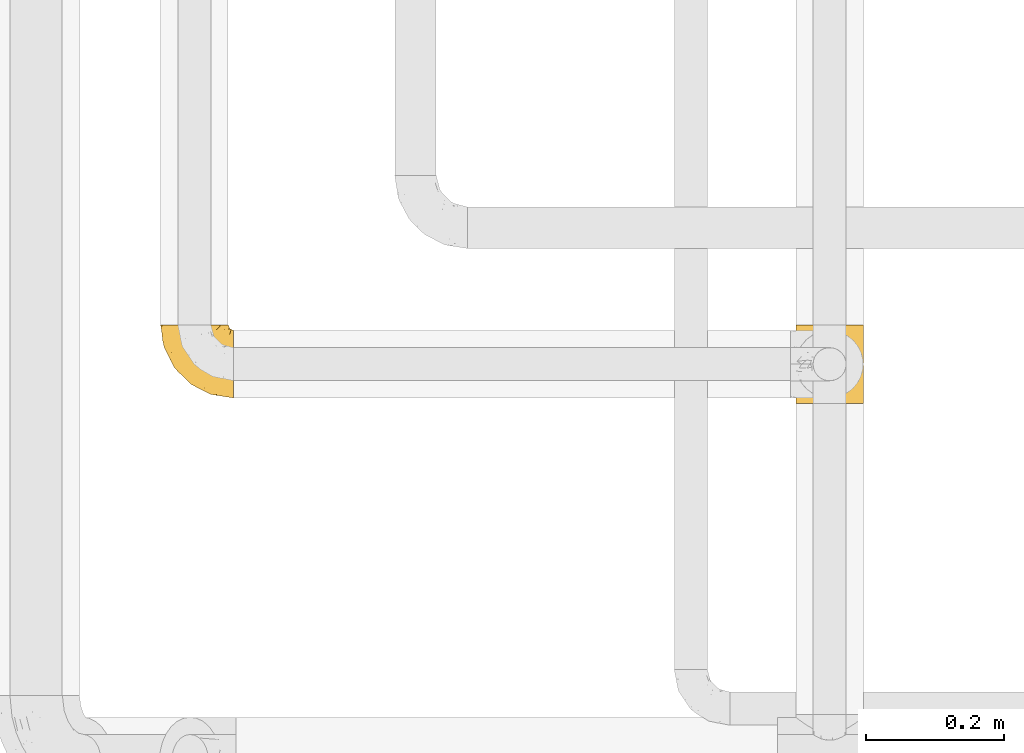
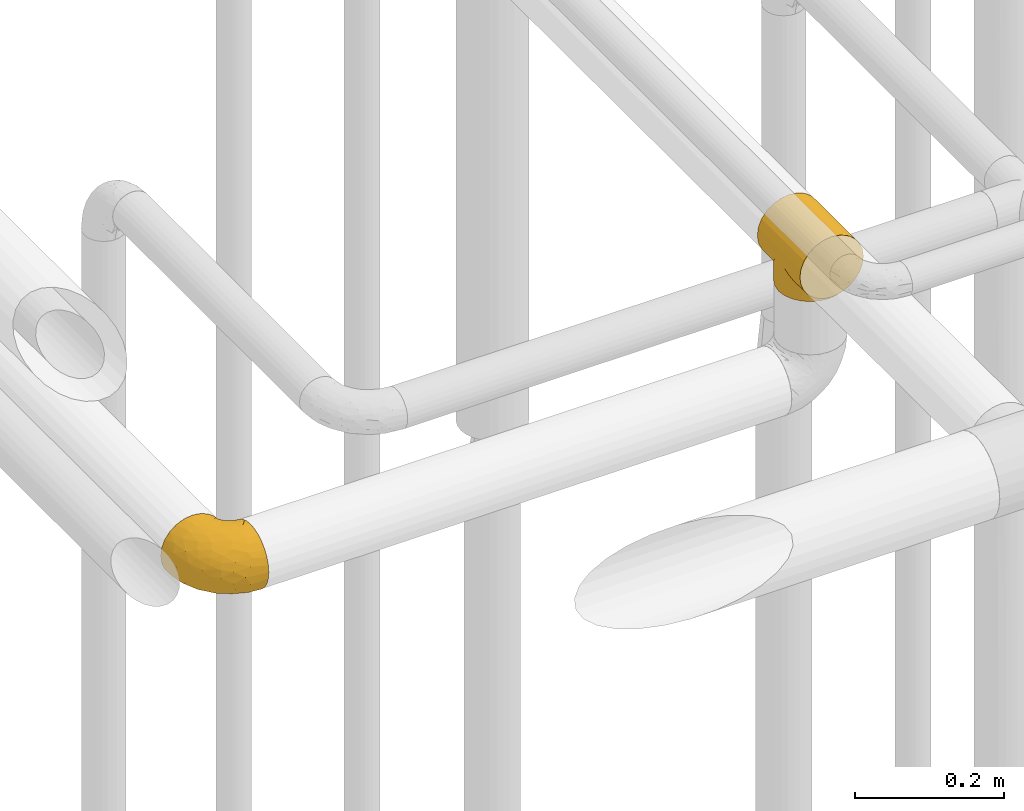
# One storey, part 421 of 827: 2 coverings.
"""IFC2X3 building model written with IfcOpenShell, lengths in millimetres."""

from ifc_helpers import new_model, entity, si_unit, converted_unit, derived_unit, direction, frame, origin, place, context, subcontext, project, spatial, faceted_brep, element, save


model = new_model("IFC2X3")

# Units and contexts
model_context = context("Model", 3, precision=0.01, world=origin(), true_north=direction((6.12303176911189e-17, 1.0)))
body_context = subcontext(model_context, "Body", "Model", "MODEL_VIEW")
ifc_project = project(units=[si_unit("LENGTHUNIT", "METRE", prefix="MILLI"), si_unit("AREAUNIT", "SQUARE_METRE"), si_unit("VOLUMEUNIT", "CUBIC_METRE"), converted_unit("PLANEANGLEUNIT", "DEGREE", entity("IfcRatioMeasure", 0.0174532925199433), si_unit("PLANEANGLEUNIT", "RADIAN"), dimensions=[0, 0, 0, 0, 0, 0, 0]), si_unit("MASSUNIT", "GRAM", prefix="KILO"), derived_unit("MASSDENSITYUNIT", [(si_unit("MASSUNIT", "GRAM", prefix="KILO"), 1), (si_unit("LENGTHUNIT", "METRE"), -3)]), derived_unit("MOMENTOFINERTIAUNIT", [(si_unit("LENGTHUNIT", "METRE"), 4)]), si_unit("TIMEUNIT", "SECOND"), si_unit("FREQUENCYUNIT", "HERTZ"), si_unit("THERMODYNAMICTEMPERATUREUNIT", "DEGREE_CELSIUS"), derived_unit("THERMALTRANSMITTANCEUNIT", [(si_unit("MASSUNIT", "GRAM", prefix="KILO"), 1), (si_unit("THERMODYNAMICTEMPERATUREUNIT", "KELVIN"), -1), (si_unit("TIMEUNIT", "SECOND"), -3)]), derived_unit("VOLUMETRICFLOWRATEUNIT", [(si_unit("LENGTHUNIT", "METRE"), 3), (si_unit("TIMEUNIT", "SECOND"), -1)]), derived_unit("MASSFLOWRATEUNIT", [(si_unit("MASSUNIT", "GRAM", prefix="KILO"), 1), (si_unit("TIMEUNIT", "SECOND"), -1)]), derived_unit("ROTATIONALFREQUENCYUNIT", [(si_unit("TIMEUNIT", "SECOND"), -1)]), si_unit("ELECTRICCURRENTUNIT", "AMPERE"), si_unit("ELECTRICVOLTAGEUNIT", "VOLT"), si_unit("POWERUNIT", "WATT"), si_unit("FORCEUNIT", "NEWTON", prefix="KILO"), si_unit("ILLUMINANCEUNIT", "LUX"), si_unit("LUMINOUSFLUXUNIT", "LUMEN"), si_unit("LUMINOUSINTENSITYUNIT", "CANDELA"), derived_unit("USERDEFINED", [(si_unit("MASSUNIT", "GRAM", prefix="KILO"), -1), (si_unit("LENGTHUNIT", "METRE"), -2), (si_unit("TIMEUNIT", "SECOND"), 3), (si_unit("LUMINOUSFLUXUNIT", "LUMEN"), 1)]), derived_unit("LINEARVELOCITYUNIT", [(si_unit("LENGTHUNIT", "METRE"), 1), (si_unit("TIMEUNIT", "SECOND"), -1)]), si_unit("PRESSUREUNIT", "PASCAL"), derived_unit("USERDEFINED", [(si_unit("LENGTHUNIT", "METRE"), -2), (si_unit("MASSUNIT", "GRAM", prefix="KILO"), 1), (si_unit("TIMEUNIT", "SECOND"), -2)]), derived_unit("LINEARFORCEUNIT", [(si_unit("MASSUNIT", "GRAM", prefix="KILO"), 1), (si_unit("LENGTHUNIT", "METRE"), 1), (si_unit("TIMEUNIT", "SECOND"), -2), (si_unit("LENGTHUNIT", "METRE"), -1)]), derived_unit("PLANARFORCEUNIT", [(si_unit("MASSUNIT", "GRAM", prefix="KILO"), 1), (si_unit("LENGTHUNIT", "METRE"), 1), (si_unit("TIMEUNIT", "SECOND"), -2), (si_unit("LENGTHUNIT", "METRE"), -2)])], contexts=[model_context])

# Site, building, storey
site_placement = place(None, origin())
site = spatial("IfcSite", under=ifc_project, at=site_placement, CompositionType="ELEMENT")
building_placement = place(site_placement, origin())
building = spatial("IfcBuilding", under=site, at=building_placement, CompositionType="ELEMENT")
storey_placement = place(building_placement, frame((0.0, 0.0, 28200.0)))
storey = spatial("IfcBuildingStorey", under=building, at=storey_placement, Name="08", CompositionType="ELEMENT", Elevation=28200.0)

# Coverings
covering_1_placement = place(storey_placement, frame((53070.31, 16591.32, 2642.23)))
element("IfcCovering", 1, at=covering_1_placement, inside=storey, Name=":ADSK_", ObjectType=":ADSK_", PredefinedType="INSULATION", context=body_context, shape_type="Brep", body=[
    faceted_brep([(2.04, 63.68, 50.44), (1.6, 114.07, 56.99), (3.27, 114.05, 44.27), (8.18, 114.03, 32.41), (5.67, 76.64, 37.44), (13.2, 88.74, 25.3), (15.99, 114.02, 22.23), (8.92, 82.85, 31.21), (1.6, 57.07, 57.07), (2.04, 50.44, 50.46), (1.6, 0.07, 57.15), (46.1, 105.71, 8.29), (44.38, 114.0, 8.68), (47.57, 114.0, 8.26), (3.39, 70.22, 43.88), (50.75, 106.15, 7.85), (50.75, 114.0, 7.84), (47.57, 0.0, 8.41), (50.75, 7.85, 7.98), (50.75, 0.0, 8.0), (18.57, 94.17, 19.86), (26.17, 114.01, 14.42), (32.1, 114.01, 11.97), (38.02, 114.0, 9.51), (37.11, 104.01, 10.0), (41.45, 105.26, 8.74), (25.1, 98.94, 15.08), (32.77, 102.75, 11.26), (41.2, 114.0, 9.1), (53.93, 114.0, 8.26), (57.11, 114.0, 8.68), (55.89, 105.61, 8.4), (61.04, 105.06, 8.94), (60.29, 114.0, 9.1), (63.47, 114.0, 9.51), (70.52, 102.0, 12.01), (69.39, 114.01, 11.97), (75.32, 114.01, 14.42), (65.78, 103.53, 10.47), (78.69, 97.44, 16.58), (80.41, 114.01, 18.33), (85.44, 91.84, 22.2), (74.6, 99.72, 14.29), (53.32, 105.88, 8.12), (85.5, 114.02, 22.23), (90.79, 85.52, 28.53), (93.31, 114.03, 32.41), (94.84, 78.75, 35.33), (98.22, 114.05, 44.27), (99.34, 64.41, 49.71), (99.9, 114.07, 56.99), (53.32, 8.12, 8.26), (97.67, 71.67, 42.43), (99.9, 57.07, 57.07), (99.34, 49.71, 49.73), (99.9, 0.07, 57.15), (75.32, 0.13, 99.71), (63.47, 0.13, 104.62), (50.75, 0.13, 106.3), (38.02, 0.13, 104.62), (26.17, 0.13, 99.71), (15.99, 0.12, 91.9), (8.18, 0.1, 81.72), (3.27, 0.08, 69.87), (3.27, 0.05, 44.42), (8.18, 0.03, 32.57), (15.99, 0.02, 22.39), (26.17, 0.01, 14.58), (32.1, 0.01, 12.13), (38.02, 0.0, 9.67), (41.2, 0.0, 9.25), (44.38, 0.0, 8.83), (53.93, 0.0, 8.41), (57.11, 0.0, 8.83), (60.29, 0.0, 9.25), (63.47, 0.0, 9.67), (69.39, 0.01, 12.13), (75.32, 0.01, 14.58), (80.41, 0.01, 18.49), (85.5, 0.02, 22.39), (93.31, 0.03, 32.57), (98.22, 0.05, 44.42), (98.22, 0.08, 69.87), (93.31, 0.1, 81.72), (85.5, 0.12, 91.9), (3.27, 114.08, 69.71), (8.18, 114.1, 81.56), (15.99, 114.12, 91.74), (26.17, 114.13, 99.55), (38.02, 114.13, 104.46), (50.75, 114.13, 106.14), (63.47, 114.13, 104.46), (75.32, 114.13, 99.55), (85.5, 114.12, 91.74), (93.31, 114.1, 81.56), (98.22, 114.08, 69.71), (3.39, 43.88, 43.91), (5.67, 37.44, 37.49), (46.1, 8.29, 8.43), (8.92, 31.21, 31.28), (13.2, 25.3, 25.39), (41.45, 8.74, 8.87), (18.57, 19.86, 19.96), (25.1, 15.08, 15.19), (37.11, 10.0, 10.13), (32.77, 11.26, 11.38), (70.52, 12.01, 12.13), (65.78, 10.47, 10.6), (78.69, 16.58, 16.69), (61.04, 8.94, 9.07), (85.44, 22.2, 22.3), (74.6, 14.29, 14.41), (55.89, 8.4, 8.53), (94.84, 35.33, 35.39), (97.67, 42.43, 42.47), (90.79, 28.53, 28.61), (3.27, 69.71, 0.05), (8.18, 81.56, 0.03), (15.99, 91.74, 0.02), (26.17, 99.55, 0.01), (32.1, 102.01, 0.01), (38.02, 104.46, 0.0), (41.2, 104.88, 0.0), (44.38, 105.3, 0.0), (47.57, 105.72, 0.0), (50.75, 106.14, 0.0), (53.93, 105.72, 0.0), (57.11, 105.3, 0.0), (60.29, 104.88, 0.0), (63.47, 104.46, 0.0), (69.39, 102.01, 0.01), (75.32, 99.55, 0.01), (80.41, 95.65, 0.01), (85.5, 91.74, 0.02), (93.31, 81.56, 0.03), (98.22, 69.71, 0.05), (99.9, 56.99, 0.07), (98.22, 44.27, 0.08), (93.31, 32.41, 0.1), (85.5, 22.23, 0.12), (80.41, 18.33, 0.12), (75.32, 14.42, 0.13), (69.39, 11.97, 0.13), (63.47, 9.51, 0.13), (60.29, 9.1, 0.13), (57.11, 8.68, 0.13), (53.93, 8.26, 0.13), (50.75, 7.84, 0.13), (47.57, 8.26, 0.13), (44.38, 8.68, 0.13), (41.2, 9.1, 0.13), (38.02, 9.51, 0.13), (32.1, 11.97, 0.13), (26.17, 14.42, 0.13), (15.99, 22.23, 0.12), (8.18, 32.41, 0.1), (3.27, 44.27, 0.08), (1.6, 56.99, 0.07)], [[[0, 1, 2]], [[2, 3, 4]], [[5, 3, 6]], [[5, 7, 3]], [[0, 8, 1]], [[8, 9, 10]], [[11, 12, 13]], [[4, 14, 2]], [[7, 4, 3]], [[0, 2, 14]], [[15, 13, 16]], [[17, 18, 19]], [[20, 6, 21]], [[22, 23, 24]], [[15, 11, 13]], [[23, 25, 24]], [[26, 20, 21]], [[27, 21, 22]], [[27, 22, 24]], [[25, 12, 11]], [[25, 23, 28, 12]], [[26, 21, 27]], [[6, 20, 5]], [[29, 30, 31]], [[32, 30, 33, 34]], [[35, 36, 37]], [[38, 36, 35]], [[38, 32, 34]], [[39, 37, 40]], [[41, 39, 40]], [[35, 37, 39, 42]], [[43, 16, 29]], [[40, 44, 41]], [[45, 44, 46]], [[47, 46, 48]], [[49, 48, 50]], [[47, 45, 46]], [[16, 43, 15]], [[51, 19, 18]], [[49, 52, 48]], [[53, 49, 50]], [[54, 53, 55]], [[30, 32, 31]], [[47, 48, 52]], [[36, 38, 34]], [[44, 45, 41]], [[29, 31, 43]], [[56, 57, 58, 59, 60, 61, 62, 63, 10, 64, 65, 66, 67, 68, 69, 70, 71, 17, 19, 72, 73, 74, 75, 76, 77, 78, 79, 80, 81, 55, 82, 83, 84]], [[85, 86, 87, 88, 89, 90, 91, 92, 93, 94, 95, 50, 48, 46, 44, 40, 37, 36, 34, 33, 30, 29, 16, 13, 12, 28, 23, 22, 21, 6, 3, 2, 1]], [[88, 87, 61, 60]], [[58, 90, 89, 59]], [[89, 88, 60, 59]], [[62, 86, 85, 63]], [[1, 8, 10, 63, 85]], [[61, 87, 86, 62]], [[96, 97, 64]], [[18, 17, 98]], [[9, 96, 64]], [[10, 9, 64]], [[65, 99, 100]], [[65, 64, 97]], [[71, 101, 98]], [[65, 100, 66]], [[99, 65, 97]], [[102, 103, 67]], [[104, 68, 105]], [[104, 101, 69]], [[68, 104, 69]], [[103, 105, 67]], [[66, 102, 67]], [[101, 71, 70, 69]], [[68, 67, 105]], [[98, 17, 71]], [[102, 66, 100]], [[106, 76, 107]], [[106, 77, 76]], [[77, 108, 78]], [[109, 75, 74, 73]], [[110, 78, 108]], [[111, 108, 77, 106]], [[19, 51, 72]], [[109, 73, 112]], [[72, 51, 112]], [[76, 75, 107]], [[110, 79, 78]], [[75, 109, 107]], [[113, 114, 81]], [[114, 54, 81]], [[79, 115, 80]], [[115, 79, 110]], [[113, 80, 115]], [[113, 81, 80]], [[54, 55, 81]], [[112, 73, 72]], [[53, 50, 95, 82, 55]], [[82, 95, 94, 83]], [[94, 93, 84, 83]], [[84, 93, 92, 56]], [[56, 92, 91, 57]], [[57, 91, 90, 58]], [[116, 117, 118, 119, 120, 121, 122, 123, 124, 125, 126, 127, 128, 129, 130, 131, 132, 133, 134, 135, 136, 137, 138, 139, 140, 141, 142, 143, 144, 145, 146, 147, 148, 149, 150, 151, 152, 153, 154, 155, 156, 157]], [[25, 123, 122, 121]], [[119, 118, 20]], [[15, 124, 11]], [[27, 120, 119]], [[124, 15, 125]], [[124, 123, 11]], [[120, 24, 121]], [[26, 27, 119]], [[20, 26, 119]], [[24, 120, 27]], [[25, 121, 24]], [[118, 5, 20]], [[7, 5, 117]], [[117, 5, 118]], [[4, 117, 116]], [[0, 116, 157]], [[4, 7, 117]], [[0, 14, 116]], [[8, 0, 157]], [[4, 116, 14]], [[123, 25, 11]], [[9, 157, 156]], [[156, 155, 97]], [[100, 155, 154]], [[100, 99, 155]], [[9, 8, 157]], [[98, 149, 148]], [[97, 96, 156]], [[99, 97, 155]], [[9, 156, 96]], [[18, 148, 147]], [[102, 154, 153]], [[152, 151, 104]], [[18, 98, 148]], [[151, 101, 104]], [[103, 102, 153]], [[105, 153, 152]], [[105, 152, 104]], [[101, 149, 98]], [[101, 151, 150, 149]], [[103, 153, 105]], [[154, 102, 100]], [[146, 145, 112]], [[109, 145, 144, 143]], [[106, 142, 141]], [[107, 142, 106]], [[107, 109, 143]], [[108, 141, 140]], [[110, 108, 140]], [[106, 141, 108, 111]], [[51, 147, 146]], [[140, 139, 110]], [[115, 139, 138]], [[113, 138, 137]], [[54, 137, 136]], [[113, 115, 138]], [[147, 51, 18]], [[54, 114, 137]], [[53, 54, 136]], [[145, 109, 112]], [[113, 137, 114]], [[142, 107, 143]], [[139, 115, 110]], [[146, 112, 51]], [[49, 136, 135]], [[135, 134, 47]], [[45, 134, 133]], [[45, 47, 134]], [[43, 125, 15]], [[49, 53, 136]], [[32, 129, 128, 127]], [[47, 52, 135]], [[49, 135, 52]], [[31, 127, 126]], [[131, 35, 42, 39]], [[125, 43, 126]], [[39, 132, 131]], [[130, 129, 38]], [[43, 31, 126]], [[41, 133, 132]], [[41, 132, 39]], [[35, 130, 38]], [[32, 127, 31]], [[35, 131, 130]], [[129, 32, 38]], [[133, 41, 45]]]),
])
covering_2_placement = place(storey_placement, frame((52147.53, 16597.64, 2447.42)))
element("IfcCovering", 2, at=covering_2_placement, inside=storey, Name=":ADSK_", ObjectType=":ADSK_", PredefinedType="INSULATION", context=body_context, shape_type="Brep", body=[
    faceted_brep([(107.75, 50.75, 99.9), (107.75, 39.8, 98.66), (107.75, 29.41, 95.02), (107.75, 20.09, 89.17), (107.75, 12.31, 81.38), (107.75, 6.46, 72.06), (107.75, 2.83, 61.68), (107.75, 1.6, 50.75), (107.75, 2.83, 39.8), (107.75, 6.47, 29.41), (107.75, 12.32, 20.09), (107.75, 20.11, 12.31), (107.75, 29.43, 6.46), (107.75, 39.81, 2.83), (107.75, 50.75, 1.6), (107.75, 56.45, 2.24), (107.75, 61.69, 2.83), (107.75, 66.88, 4.65), (107.75, 72.08, 6.47), (107.75, 81.4, 12.32), (107.75, 89.18, 20.11), (107.75, 95.03, 29.43), (107.75, 98.66, 39.81), (107.75, 99.9, 50.75), (107.75, 98.66, 61.69), (107.75, 95.02, 72.08), (107.75, 89.17, 81.4), (107.75, 81.38, 89.18), (107.75, 72.06, 95.03), (107.75, 66.87, 96.85), (107.75, 61.68, 98.66), (107.75, 56.45, 99.25), (107.75, 53.6, 99.57), (98.22, 107.75, 38.02), (93.31, 107.75, 26.17), (89.4, 107.75, 21.08), (85.5, 107.75, 15.99), (80.41, 107.75, 12.09), (75.32, 107.75, 8.18), (69.39, 107.75, 5.73), (63.47, 107.75, 3.27), (56.48, 107.75, 2.35), (53.61, 107.75, 1.97), (50.75, 107.75, 1.6), (38.02, 107.75, 3.27), (26.17, 107.75, 8.18), (15.99, 107.75, 15.99), (8.18, 107.75, 26.17), (3.27, 107.75, 38.02), (1.6, 107.75, 50.75), (3.27, 107.75, 63.47), (8.18, 107.75, 75.32), (15.99, 107.75, 85.5), (26.17, 107.75, 93.31), (38.02, 107.75, 98.22), (50.75, 107.75, 99.9), (56.48, 107.75, 99.14), (63.47, 107.75, 98.22), (69.39, 107.75, 95.77), (75.32, 107.75, 93.31), (80.41, 107.75, 89.4), (85.5, 107.75, 85.5), (89.4, 107.75, 80.41), (93.31, 107.75, 75.32), (98.22, 107.75, 63.47), (99.9, 107.75, 50.75), (27.53, 39.38, 59.31), (25.32, 49.75, 73.08), (16.29, 57.38, 63.72), (6.79, 74.94, 50.75), (4.51, 85.97, 58.64), (3.51, 95.66, 50.75), (17.47, 67.82, 76.74), (7.6, 83.09, 67.68), (12.27, 89.16, 78.92), (70.89, 37.01, 94.31), (87.17, 43.46, 98.76), (67.3, 51.79, 98.4), (31.65, 85.58, 94.57), (33.58, 62.84, 89.91), (47.23, 62.77, 96.32), (43.26, 88.17, 98.79), (55.08, 85.93, 99.9), (53.99, 91.42, 99.9), (52.9, 96.91, 99.9), (52.36, 99.62, 99.9), (51.82, 102.33, 99.9), (21.5, 82.57, 87.31), (89.94, 32.75, 95.61), (60.45, 13.79, 60.43), (83.0, 6.77, 65.24), (64.79, 16.46, 72.87), (85.93, 55.08, 99.9), (81.31, 58.17, 99.9), (76.69, 61.26, 99.9), (72.06, 64.35, 99.9), (67.44, 67.44, 99.9), (88.74, 24.18, 90.65), (45.98, 23.37, 63.14), (47.13, 49.76, 91.89), (89.4, 9.84, 75.25), (95.66, 3.51, 50.75), (28.5, 55.75, 82.18), (42.81, 42.34, 85.08), (38.28, 37.78, 76.93), (45.35, 21.87, 50.75), (33.61, 33.61, 50.75), (82.57, 17.1, 83.02), (105.04, 51.28, 99.9), (102.33, 51.82, 99.9), (96.91, 52.9, 99.9), (91.42, 53.99, 99.9), (65.92, 28.01, 87.13), (53.11, 28.99, 80.85), (54.37, 69.9, 99.17), (74.94, 6.79, 50.75), (64.35, 72.06, 99.9), (61.26, 76.69, 99.9), (58.17, 81.31, 99.9), (21.87, 45.35, 50.75), (34.79, 34.79, 67.61), (48.48, 25.72, 72.25), (60.15, 14.33, 50.75), (14.33, 60.15, 50.75), (99.07, 62.38, 98.69), (60.55, 100.57, 99.01), (64.18, 91.06, 98.79), (64.36, 97.66, 98.29), (103.17, 97.55, 68.51), (101.69, 93.65, 76.82), (87.75, 66.85, 98.54), (89.38, 61.93, 99.3), (88.34, 101.4, 83.57), (82.14, 100.07, 89.47), (94.51, 101.36, 75.76), (89.64, 95.94, 84.86), (98.41, 96.3, 75.89), (99.71, 101.98, 64.77), (89.37, 85.88, 90.83), (88.21, 78.88, 94.62), (95.2, 82.8, 90.37), (79.14, 102.58, 91.18), (101.22, 82.88, 88.65), (99.41, 88.57, 84.11), (84.72, 88.67, 91.75), (97.47, 69.08, 96.86), (102.19, 102.19, 50.75), (104.02, 100.06, 58.97), (82.66, 70.56, 98.37), (95.42, 91.07, 83.91), (78.67, 77.56, 97.52), (72.69, 96.59, 95.55), (66.46, 86.38, 98.76), (75.3, 91.79, 95.26), (72.74, 81.71, 98.04), (82.93, 94.11, 90.65), (99.27, 76.09, 93.51), (93.51, 76.91, 94.16), (67.35, 81.44, 99.1), (94.51, 101.37, 25.73), (82.94, 94.12, 10.84), (88.33, 101.41, 17.92), (89.64, 95.96, 16.64), (103.62, 96.22, 30.44), (87.74, 66.85, 2.95), (89.38, 61.94, 2.19), (81.31, 58.17, 1.6), (97.47, 69.1, 4.63), (99.41, 88.58, 17.39), (51.28, 105.04, 1.6), (52.9, 96.91, 1.6), (51.82, 102.33, 1.6), (101.21, 82.9, 12.86), (95.19, 82.82, 11.13), (64.36, 97.66, 3.2), (72.69, 96.59, 5.94), (79.14, 102.58, 10.31), (99.28, 76.13, 8.0), (93.51, 76.93, 7.34), (60.55, 100.57, 2.48), (66.46, 86.38, 2.73), (63.96, 90.86, 2.64), (96.91, 52.9, 1.6), (99.06, 62.39, 2.8), (99.7, 101.98, 36.71), (53.99, 91.42, 1.6), (55.08, 85.93, 1.6), (103.3, 99.49, 38.59), (102.33, 51.82, 1.6), (99.62, 52.36, 1.6), (76.69, 61.26, 1.6), (82.66, 70.56, 3.12), (95.42, 91.09, 17.59), (72.06, 64.35, 1.6), (78.68, 77.6, 3.98), (88.2, 78.89, 6.87), (72.75, 81.71, 3.45), (84.74, 88.69, 9.76), (91.42, 53.99, 1.6), (85.93, 55.08, 1.6), (98.41, 96.31, 25.62), (89.37, 85.9, 10.67), (67.35, 81.45, 2.39), (61.26, 76.69, 1.6), (75.3, 91.79, 6.23), (82.13, 100.07, 12.02), (58.17, 81.31, 1.6), (64.35, 72.06, 1.6), (67.44, 67.44, 1.6), (54.08, 69.6, 2.4), (4.51, 85.97, 42.85), (21.5, 82.57, 14.18), (33.43, 63.16, 11.56), (28.5, 55.81, 19.27), (17.47, 67.81, 24.75), (25.36, 49.73, 28.37), (90.18, 32.55, 5.95), (86.97, 43.23, 2.79), (43.26, 88.17, 2.71), (16.29, 57.38, 37.78), (7.6, 83.08, 33.81), (12.27, 89.16, 22.57), (31.65, 85.58, 6.92), (64.79, 16.46, 28.61), (83.0, 6.77, 36.24), (60.44, 13.8, 41.05), (38.35, 37.71, 24.55), (34.8, 34.8, 33.88), (71.54, 36.83, 7.11), (45.94, 23.39, 38.38), (27.53, 39.38, 42.18), (82.57, 17.12, 18.46), (88.74, 24.19, 10.84), (53.19, 28.89, 20.69), (48.49, 25.69, 29.27), (67.28, 51.77, 3.1), (52.32, 45.66, 9.18), (89.4, 9.85, 26.23), (65.75, 28.11, 14.34), (46.73, 62.27, 5.46), (42.82, 42.35, 16.39)], [[[0, 1, 2, 3, 4, 5, 6, 7, 8, 9, 10, 11, 12, 13, 14, 15, 16, 17, 18, 19, 20, 21, 22, 23, 24, 25, 26, 27, 28, 29, 30, 31, 32]], [[33, 34, 35, 36, 37, 38, 39, 40, 41, 42, 43, 44, 45, 46, 47, 48, 49, 50, 51, 52, 53, 54, 55, 56, 57, 58, 59, 60, 61, 62, 63, 64, 65]], [[66, 67, 68]], [[69, 70, 71]], [[68, 72, 73]], [[73, 72, 74]], [[75, 76, 77]], [[78, 79, 80]], [[51, 50, 73]], [[81, 82, 83, 84, 85, 86, 55]], [[52, 87, 53]], [[74, 52, 51]], [[2, 1, 88]], [[89, 90, 91]], [[77, 92, 93, 94, 95, 96]], [[55, 54, 81]], [[78, 53, 87]], [[5, 90, 6]], [[88, 76, 75]], [[97, 3, 2]], [[89, 91, 98]], [[99, 80, 79]], [[90, 5, 100]], [[74, 87, 52]], [[100, 5, 4]], [[90, 101, 6]], [[79, 102, 103]], [[102, 67, 104]], [[105, 98, 106]], [[107, 4, 3]], [[76, 0, 108, 109, 110, 111, 92]], [[107, 112, 113]], [[114, 77, 96]], [[89, 115, 90]], [[114, 96, 116, 117, 118, 82]], [[75, 97, 88]], [[119, 66, 68]], [[50, 71, 70]], [[100, 91, 90]], [[99, 77, 80]], [[102, 104, 103]], [[97, 107, 3]], [[80, 81, 78]], [[107, 97, 112]], [[68, 73, 70]], [[66, 98, 120]], [[78, 81, 54]], [[114, 81, 80]], [[53, 78, 54]], [[78, 87, 79]], [[102, 87, 72]], [[79, 103, 99]], [[4, 107, 100]], [[91, 100, 107]], [[88, 97, 2]], [[112, 97, 75]], [[99, 112, 75]], [[103, 104, 113]], [[91, 121, 98]], [[89, 105, 122, 115]], [[101, 90, 115]], [[101, 7, 6]], [[88, 1, 76]], [[0, 76, 1]], [[92, 77, 76]], [[73, 74, 51]], [[87, 74, 72]], [[81, 114, 82]], [[77, 114, 80]], [[87, 102, 79]], [[67, 102, 72]], [[68, 67, 72]], [[67, 120, 104]], [[120, 121, 104]], [[104, 121, 113]], [[121, 120, 98]], [[91, 107, 113]], [[91, 113, 121]], [[103, 113, 112]], [[66, 119, 106]], [[105, 89, 98]], [[68, 69, 123, 119]], [[67, 66, 120]], [[98, 66, 106]], [[50, 49, 71]], [[50, 70, 73]], [[112, 99, 103]], [[77, 99, 75]], [[69, 68, 70]], [[29, 124, 110]], [[84, 83, 125]], [[126, 82, 118]], [[59, 58, 127]], [[25, 128, 129]], [[130, 93, 131]], [[132, 62, 133]], [[134, 135, 136]], [[137, 65, 64]], [[64, 134, 137]], [[138, 139, 140]], [[111, 110, 124, 92]], [[134, 136, 137]], [[134, 64, 63]], [[133, 61, 141]], [[125, 58, 57]], [[142, 143, 140]], [[142, 26, 143]], [[127, 83, 82]], [[28, 124, 29]], [[108, 0, 32, 31, 30, 110, 109]], [[30, 29, 110]], [[135, 144, 138]], [[28, 145, 124]], [[57, 56, 55, 86, 85, 84]], [[146, 147, 23]], [[24, 23, 147]], [[25, 143, 26]], [[95, 94, 148]], [[24, 128, 25]], [[149, 138, 143]], [[124, 145, 131]], [[127, 58, 125]], [[150, 148, 139]], [[127, 126, 151]], [[151, 59, 127]], [[152, 151, 126]], [[153, 154, 155]], [[153, 133, 141]], [[145, 28, 27]], [[142, 156, 27]], [[157, 148, 130]], [[61, 133, 62]], [[134, 132, 135]], [[147, 128, 24]], [[65, 137, 146]], [[146, 137, 147]], [[128, 137, 136]], [[137, 128, 147]], [[128, 136, 129]], [[149, 129, 136]], [[25, 129, 143]], [[158, 152, 117]], [[152, 118, 117]], [[153, 151, 152]], [[158, 116, 154]], [[144, 150, 138]], [[153, 152, 158]], [[133, 153, 155]], [[133, 155, 132]], [[141, 61, 60]], [[135, 132, 155]], [[134, 63, 132]], [[144, 135, 155]], [[135, 138, 149]], [[155, 154, 144]], [[150, 154, 96]], [[154, 150, 144]], [[148, 94, 130]], [[82, 126, 127]], [[118, 152, 126]], [[150, 96, 95]], [[139, 148, 157]], [[150, 95, 148]], [[93, 92, 131]], [[130, 145, 156]], [[130, 94, 93]], [[84, 125, 57]], [[127, 125, 83]], [[140, 139, 157]], [[150, 139, 138]], [[140, 157, 142]], [[138, 140, 143]], [[156, 142, 157]], [[27, 26, 142]], [[130, 156, 157]], [[145, 27, 156]], [[132, 63, 62]], [[124, 131, 92]], [[130, 131, 145]], [[129, 149, 143]], [[135, 149, 136]], [[60, 151, 141]], [[59, 151, 60]], [[141, 151, 153]], [[116, 96, 154]], [[153, 158, 154]], [[158, 117, 116]], [[34, 33, 159]], [[160, 161, 162]], [[22, 21, 163]], [[164, 165, 166]], [[19, 18, 167]], [[168, 21, 20]], [[169, 43, 42, 41, 40, 170, 171]], [[172, 173, 168]], [[174, 38, 175]], [[176, 37, 36]], [[177, 164, 178]], [[40, 179, 170]], [[180, 181, 175]], [[17, 182, 183]], [[65, 146, 184]], [[185, 174, 186]], [[23, 22, 187]], [[174, 39, 38]], [[15, 14, 188, 189, 182, 16]], [[179, 40, 39]], [[190, 191, 164]], [[192, 163, 168]], [[33, 184, 159]], [[178, 173, 172]], [[193, 194, 191]], [[18, 183, 167]], [[173, 178, 195]], [[196, 197, 194]], [[198, 199, 183, 182]], [[182, 17, 16]], [[18, 17, 183]], [[200, 159, 184]], [[192, 168, 201]], [[187, 163, 200]], [[202, 203, 180]], [[185, 179, 174]], [[160, 204, 205]], [[206, 181, 180]], [[206, 180, 203]], [[199, 165, 183]], [[165, 164, 167]], [[172, 177, 178]], [[200, 192, 162]], [[205, 161, 160]], [[65, 184, 33]], [[163, 187, 22]], [[175, 204, 180]], [[174, 181, 186]], [[204, 196, 202]], [[197, 160, 162]], [[196, 207, 202]], [[205, 204, 176]], [[196, 204, 160]], [[176, 204, 175]], [[205, 35, 161]], [[34, 159, 161]], [[162, 161, 159]], [[200, 162, 159]], [[197, 162, 201]], [[194, 197, 201]], [[196, 160, 197]], [[191, 195, 178]], [[208, 196, 194]], [[186, 181, 206]], [[175, 181, 174]], [[191, 190, 193]], [[193, 208, 194]], [[195, 194, 201]], [[178, 164, 191]], [[168, 163, 21]], [[166, 165, 199]], [[166, 190, 164]], [[187, 200, 184]], [[184, 146, 187]], [[23, 187, 146]], [[174, 179, 39]], [[170, 179, 185]], [[194, 195, 191]], [[173, 201, 168]], [[201, 173, 195]], [[172, 168, 20]], [[20, 19, 172]], [[177, 172, 19]], [[19, 167, 177]], [[164, 177, 167]], [[35, 205, 36]], [[35, 34, 161]], [[183, 165, 167]], [[162, 192, 201]], [[163, 192, 200]], [[175, 38, 37]], [[205, 176, 36]], [[175, 37, 176]], [[204, 202, 180]], [[207, 196, 208]], [[207, 203, 202]], [[209, 186, 206, 203, 207, 208]], [[48, 210, 71]], [[211, 212, 213]], [[214, 213, 215]], [[216, 217, 13]], [[218, 43, 169, 171, 170, 185, 186]], [[219, 220, 214]], [[47, 46, 221]], [[210, 48, 220]], [[211, 222, 212]], [[222, 45, 44]], [[221, 220, 47]], [[47, 220, 48]], [[221, 211, 214]], [[223, 224, 225]], [[211, 46, 45]], [[226, 227, 215]], [[43, 218, 44]], [[217, 216, 228]], [[227, 229, 230]], [[14, 13, 217]], [[224, 9, 8]], [[10, 231, 11]], [[11, 232, 12]], [[233, 223, 234]], [[235, 208, 193, 190, 166, 199]], [[236, 235, 228]], [[222, 44, 218]], [[106, 230, 229]], [[224, 237, 9]], [[232, 238, 228]], [[9, 237, 10]], [[115, 224, 101]], [[239, 235, 236]], [[232, 11, 231]], [[223, 231, 237]], [[224, 8, 101]], [[223, 229, 234]], [[225, 115, 122, 105]], [[216, 12, 232]], [[209, 235, 239]], [[210, 219, 69]], [[219, 214, 215]], [[230, 119, 219]], [[209, 218, 186]], [[239, 212, 222]], [[239, 222, 218]], [[45, 222, 211]], [[236, 212, 239]], [[213, 212, 240]], [[223, 237, 224]], [[231, 10, 237]], [[238, 232, 231]], [[216, 232, 228]], [[233, 231, 223]], [[236, 238, 240]], [[115, 225, 224]], [[234, 229, 227]], [[8, 7, 101]], [[235, 209, 208]], [[218, 209, 239]], [[217, 228, 235]], [[13, 12, 216]], [[235, 199, 217]], [[217, 199, 198, 182, 189, 188, 14]], [[211, 221, 46]], [[220, 221, 214]], [[71, 210, 69]], [[71, 49, 48]], [[219, 210, 220]], [[226, 215, 213]], [[211, 213, 214]], [[226, 213, 240]], [[215, 227, 230]], [[233, 240, 238]], [[234, 227, 226]], [[233, 234, 226]], [[229, 223, 225]], [[240, 233, 226]], [[233, 238, 231]], [[225, 105, 229]], [[229, 105, 106]], [[106, 119, 230]], [[123, 69, 219, 119]], [[215, 230, 219]], [[238, 236, 228]], [[212, 236, 240]]]),
])

save(model, "model.ifc")
